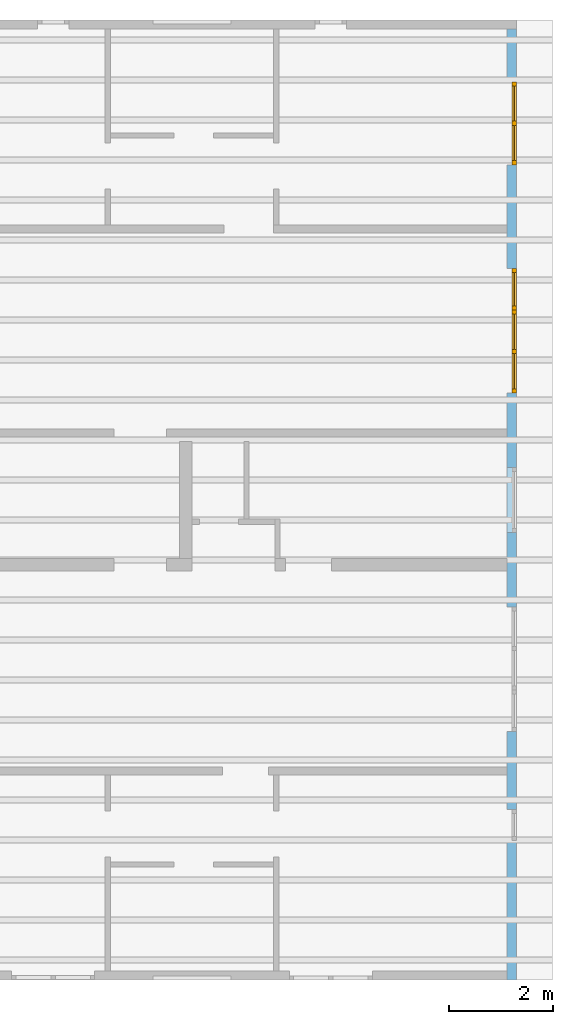
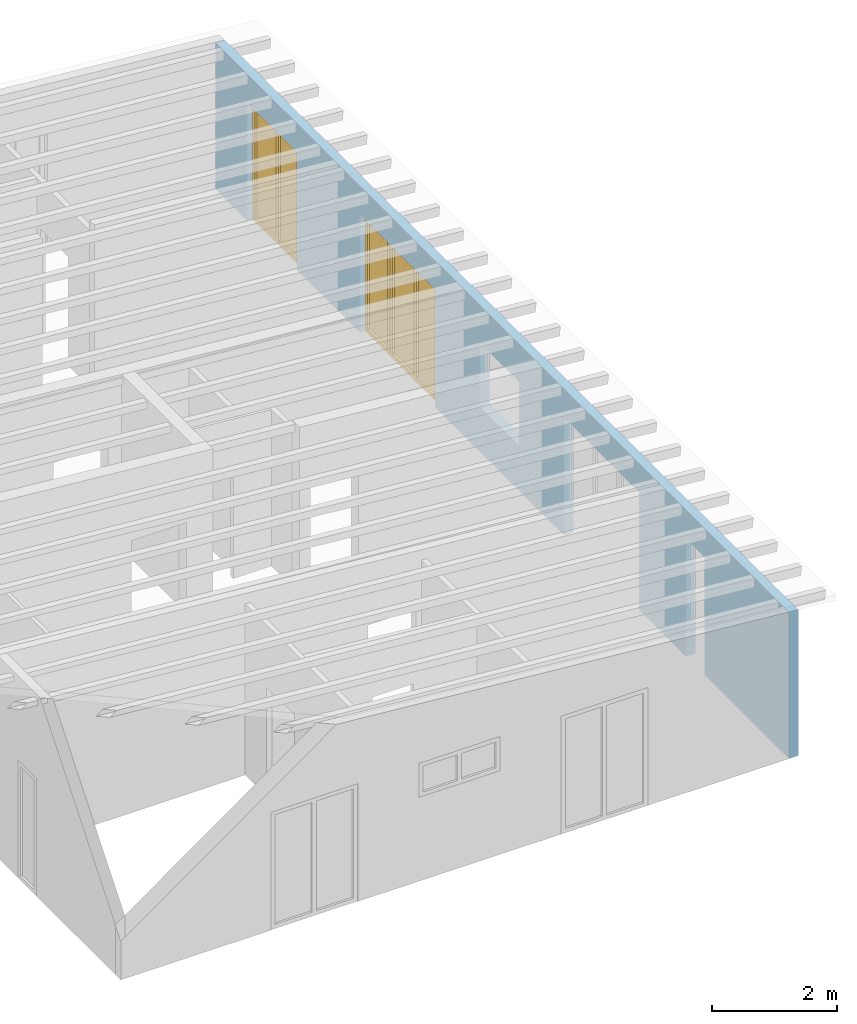
# One storey, part 10 of 13: 3 windows, 7 openings, plus 1 element that does not belong to this part.
"""IFC2X3 building model written with IfcOpenShell, lengths in millimetres."""

import ifcopenshell
import ifcopenshell.guid

model = None  # the IFC model being written
_history = None  # IfcOwnerHistory: only IFC2X3 demands one
_inside = {}  # id of a spatial element -> (the spatial element, [elements in it])
_under = {}  # id of a project, library or spatial element -> (it, [spatial elements below it])
_declared = {}  # id of a project -> (the project, [libraries it declares])
_typed = {}  # id of a type object -> (the type object, [elements of that type])
_made_of = {}  # id of a material, layer set ... -> (it, [elements and type objects made of it])


def new_model(schema):
    """Start an empty IFC model of exactly this schema.

    Asked for "IFC4X3", IfcOpenShell would pick the latest addendum, in which some entities
    have other attributes; the version numbers below select the first issue.
    IFC2X3 requires an IfcOwnerHistory on every rooted entity: one is made here for all.
    """
    global model, _history
    if schema == "IFC4X3":
        model = ifcopenshell.file(schema_version=(4, 3, 0, 0))
    else:
        model = ifcopenshell.file(schema=schema)
    _inside.clear()
    _under.clear()
    _declared.clear()
    _typed.clear()
    _made_of.clear()
    _history = None
    if model.schema == "IFC2X3":
        org = make("IfcOrganization", Name="unknown")
        user = make(
            "IfcPersonAndOrganization",
            ThePerson=make("IfcPerson", FamilyName="unknown"),
            TheOrganization=org,
        )
        app = make(
            "IfcApplication",
            ApplicationDeveloper=org,
            Version="unknown",
            ApplicationFullName="unknown",
            ApplicationIdentifier="unknown",
        )
        _history = make(
            "IfcOwnerHistory",
            OwningUser=user,
            OwningApplication=app,
            ChangeAction="ADDED",
            CreationDate=0,
        )
    return model


def make(cls, **values):
    """One entity of the class cls with the attributes given. An attribute that is None is left unset."""
    return model.create_entity(
        cls, **{name: value for name, value in values.items() if value is not None}
    )


def entity(cls, *values):
    """Any entity or typed value of the class cls, its attributes in the order of the schema. None: left unset."""
    e = model.create_entity(cls)
    for i, value in enumerate(values):
        if value is not None:
            e[i] = value
    return e


def rooted(cls, **values):
    """An entity with a GlobalId (a new one), such as an element, a storey or a relation."""
    return make(cls, GlobalId=ifcopenshell.guid.new(), OwnerHistory=_history, **values)


def si_unit(unit_type, name, prefix=None):
    """IfcSIUnit, for example si_unit("LENGTHUNIT", "METRE", prefix="MILLI")."""
    return make("IfcSIUnit", UnitType=unit_type, Prefix=prefix, Name=name)


def converted_unit(unit_type, name, factor, base, dimensions=None, offset=None):
    """IfcConversionBasedUnit, such as the inch: factor (a typed value) times the base unit."""
    return make(
        "IfcConversionBasedUnit"
        if offset is None
        else "IfcConversionBasedUnitWithOffset",
        ConversionOffset=offset,
        Dimensions=None
        if dimensions is None
        else entity("IfcDimensionalExponents", *dimensions),
        UnitType=unit_type,
        Name=name,
        ConversionFactor=make(
            "IfcMeasureWithUnit", ValueComponent=factor, UnitComponent=base
        ),
    )


def assignment(units):
    """IfcUnitAssignment: the units of a project."""
    return None if units is None else make("IfcUnitAssignment", Units=units)


def point(xyz):
    """IfcCartesianPoint."""
    return None if xyz is None else make("IfcCartesianPoint", Coordinates=xyz)


def direction(xyz):
    """IfcDirection."""
    return None if xyz is None else make("IfcDirection", DirectionRatios=xyz)


def frame(location, z_axis=None, x_axis=None):
    """IfcAxis2Placement3D, a coordinate frame: its origin and axes. An axis left out is left unset."""
    return make(
        "IfcAxis2Placement3D",
        Location=point(location),
        Axis=direction(z_axis),
        RefDirection=direction(x_axis),
    )


def frame_2d(location, x_axis=None):
    """IfcAxis2Placement2D, a coordinate frame in the plane: its origin and x axis."""
    return make(
        "IfcAxis2Placement2D", Location=point(location), RefDirection=direction(x_axis)
    )


def origin():
    """The frame at (0, 0, 0) with its axes left unset."""
    return frame((0.0, 0.0, 0.0))


def origin_with_axes():
    """The frame at (0, 0, 0) with the z axis (0, 0, 1) and the x axis (1, 0, 0) written out."""
    return frame((0.0, 0.0, 0.0), z_axis=(0.0, 0.0, 1.0), x_axis=(1.0, 0.0, 0.0))


def place(relative_to, where):
    """IfcLocalPlacement: puts the frame where relative to a parent placement (None: the world)."""
    return make(
        "IfcLocalPlacement", PlacementRelTo=relative_to, RelativePlacement=where
    )


def context(
    kind, dimensions, precision=None, world=None, true_north=None, identifier=None
):
    """IfcGeometricRepresentationContext, for example the 3D "Model" context."""
    return make(
        "IfcGeometricRepresentationContext",
        ContextIdentifier=identifier,
        ContextType=kind,
        CoordinateSpaceDimension=dimensions,
        Precision=precision,
        WorldCoordinateSystem=world,
        TrueNorth=true_north,
    )


def project(units=None, contexts=None):
    """IfcProject with its units and contexts."""
    return rooted(
        "IfcProject",
        Name="project",
        RepresentationContexts=contexts,
        UnitsInContext=assignment(units),
    )


def spatial(cls, under=None, at=None, **own):
    """A site, building, storey or space (cls), placed at a placement, below another one or the project."""
    s = rooted(cls, ObjectPlacement=at, **own)
    if under is not None:
        _under.setdefault(under.id(), (under, []))[1].append(s)
    return s


def profile(cls, at=None, kind="AREA", **sizes):
    """A parametric profile (cls). Its sizes go by their IFC names, for example OverallWidth=200.0."""
    return make(cls, ProfileType=kind, Position=at, **sizes)


def rectangle(**sizes):
    """IfcRectangleProfileDef."""
    return profile("IfcRectangleProfileDef", **sizes)


def extrude(swept, where, along, depth):
    """IfcExtrudedAreaSolid: the profile swept, set in the frame where, extruded along a direction by depth."""
    return make(
        "IfcExtrudedAreaSolid",
        SweptArea=swept,
        Position=where,
        ExtrudedDirection=direction(along),
        Depth=depth,
    )


def clip(a, b, op="DIFFERENCE"):
    """IfcBooleanClippingResult: the solid a cut by the half space b."""
    return make(
        "IfcBooleanClippingResult", Operator=op, FirstOperand=a, SecondOperand=b
    )


def halfspace(plane, agree):
    """IfcHalfSpaceSolid: all space on one side of the plane z = 0 of the frame plane."""
    return make(
        "IfcHalfSpaceSolid",
        BaseSurface=make("IfcPlane", Position=plane),
        AgreementFlag=agree,
    )


def faces_of(points, faces, orient=None, outer=None):
    """IfcFace entities. A face is a list of loops; a loop is a list of indices into points, from 0.

    orient and outer hold one flag for each loop. By default every Orientation is true, the
    first loop of a face is its IfcFaceOuterBound and the others are IfcFaceBound.
    """
    made = []
    for i, loops in enumerate(faces):
        bounds = []
        for j, loop in enumerate(loops):
            is_outer = j == 0 if outer is None else outer[i][j]
            bounds.append(
                make(
                    "IfcFaceOuterBound" if is_outer else "IfcFaceBound",
                    Bound=make("IfcPolyLoop", Polygon=[points[k] for k in loop]),
                    Orientation=True if orient is None else orient[i][j],
                )
            )
        made.append(make("IfcFace", Bounds=bounds))
    return made


def faceted_brep(points, faces, orient=None, outer=None, voids=None):
    """IfcFacetedBrep: a solid bounded by flat faces; with voids (closed shells), ...WithVoids."""
    shared = [point(p) for p in points]
    hull = make("IfcClosedShell", CfsFaces=faces_of(shared, faces, orient, outer))
    if voids is None:
        return make("IfcFacetedBrep", Outer=hull)
    return make(
        "IfcFacetedBrepWithVoids",
        Outer=hull,
        Voids=[
            make(cls, CfsFaces=faces_of(shared, fs, o, b)) for cls, fs, o, b in voids
        ],
    )


def shape(context_of_items, identifier, shape_type, items):
    """IfcShapeRepresentation: the items that make up one representation, for example the "Body"."""
    return make(
        "IfcShapeRepresentation",
        ContextOfItems=context_of_items,
        RepresentationIdentifier=identifier,
        RepresentationType=shape_type,
        Items=items,
    )


def material(Name=None, Category=None):
    """IfcMaterial."""
    return make("IfcMaterial", Name=Name, Category=Category)


def layer(
    of_material, thickness, ventilated=None, Name=None, Category=None, Priority=None
):
    """IfcMaterialLayer: one layer of a wall or slab, of a material (None: an air gap)."""
    return make(
        "IfcMaterialLayer",
        Material=of_material,
        LayerThickness=thickness,
        IsVentilated=ventilated,
        Name=Name,
        Category=Category,
        Priority=Priority,
    )


def layer_set(layers, Name=None):
    """IfcMaterialLayerSet."""
    return make("IfcMaterialLayerSet", MaterialLayers=layers, LayerSetName=Name)


def layer_usage(for_layer_set, set_direction, sense, offset, extent=None):
    """IfcMaterialLayerSetUsage: how a layer set lies in its element."""
    return make(
        "IfcMaterialLayerSetUsage",
        ForLayerSet=for_layer_set,
        LayerSetDirection=set_direction,
        DirectionSense=sense,
        OffsetFromReferenceLine=offset,
        ReferenceExtent=extent,
    )


def made_of(thing, what):
    """Note that an element or type object is made of a material, layer set ...; save() writes the relation."""
    if what is not None:
        _made_of.setdefault(what.id(), (what, []))[1].append(thing)
    return thing


def element(
    cls,
    number,
    at=None,
    inside=None,
    cuts=None,
    type_object=None,
    material=None,
    context=None,
    identifier="Body",
    shape_type=None,
    held_by="IfcProductDefinitionShape",
    body=None,
    shapes=None,
    **own,
):
    """One element of the class cls, such as IfcWall. Its Tag is "e" and its number.

    at: its placement. inside: the storey or other place that contains it. cuts: it is an
    opening in that element (IfcRelVoidsElement). A single representation is given by context,
    identifier, shape_type and body (its items); several are given by shapes. held_by: the class
    of the entity that holds the representations. save() writes the other relations.
    """
    e = rooted(cls, Tag="e%d" % number, ObjectPlacement=at, **own)
    if body is not None:
        shapes = [shape(context, identifier, shape_type, body)]
    if shapes is not None:
        e.Representation = make(held_by, Representations=shapes)
    if inside is not None:
        _inside.setdefault(inside.id(), (inside, []))[1].append(e)
    if cuts is not None:
        rooted(
            "IfcRelVoidsElement", RelatingBuildingElement=cuts, RelatedOpeningElement=e
        )
    if type_object is not None:
        _typed.setdefault(type_object.id(), (type_object, []))[1].append(e)
    return made_of(e, material)


def fill(opening, filler):
    """IfcRelFillsElement: the door or window that sits in an opening."""
    return rooted(
        "IfcRelFillsElement",
        RelatingOpeningElement=opening,
        RelatedBuildingElement=filler,
    )


def aggregate(whole, parts):
    """IfcRelAggregates: a whole, such as a stair, and the parts it consists of."""
    return rooted("IfcRelAggregates", RelatingObject=whole, RelatedObjects=parts)


def save(model, path):
    """Write the relations noted so far, then the file.

    IfcRelAggregates (storeys below a building ...), IfcRelContainedInSpatialStructure (elements
    in a storey), IfcRelDefinesByType, IfcRelAssociatesMaterial and IfcRelDeclares: one each for
    every whole, place, type object, material and project.
    """
    for whole, parts in _under.values():
        aggregate(whole, parts)
    for where, things in _inside.values():
        rooted(
            "IfcRelContainedInSpatialStructure",
            RelatedElements=things,
            RelatingStructure=where,
        )
    for kind, things in _typed.values():
        rooted("IfcRelDefinesByType", RelatedObjects=things, RelatingType=kind)
    for what, things in _made_of.values():
        rooted("IfcRelAssociatesMaterial", RelatedObjects=things, RelatingMaterial=what)
    for by, libraries in _declared.values():
        rooted("IfcRelDeclares", RelatingContext=by, RelatedDefinitions=libraries)
    model.write(path)


model = new_model("IFC2X3")

# Units and contexts
model_context = context("Model", 3, precision=1e-05, world=origin())
plan_context = context("Plan", 3, precision=1e-05, world=origin())
ifc_project = project(units=[si_unit("LENGTHUNIT", "METRE", prefix="MILLI"), converted_unit("PLANEANGLEUNIT", "DEGREE", entity("IfcPlaneAngleMeasure", 0.0174532925199433), si_unit("PLANEANGLEUNIT", "RADIAN"), dimensions=[0, 0, 0, 0, 0, 0, 0]), si_unit("AREAUNIT", "SQUARE_METRE"), si_unit("VOLUMEUNIT", "CUBIC_METRE")], contexts=[model_context, plan_context])

# Building, storey
building_placement = place(None, origin())
building = spatial("IfcBuilding", under=ifc_project, at=building_placement, CompositionType="ELEMENT")
storey_placement = place(building_placement, frame((0.0, 0.0, 4770.0), z_axis=(0.0, 0.0, 1.0), x_axis=(1.0, 0.0, 0.0)))
storey = spatial("IfcBuildingStorey", under=building, at=storey_placement, Name="Geschoss", CompositionType="ELEMENT", Elevation=4770.0)

# Wall, openings, windows
ifc_material_1 = material()
ifc_layer = layer(ifc_material_1, 175.000000044703)
ifc_layer_set = layer_set([ifc_layer])
ifc_layer_usage = layer_usage(ifc_layer_set, "AXIS2", "POSITIVE", 0.0)
wall_placement = place(storey_placement, frame((33688.3517822139, -8691.5625, 0.0), z_axis=(0.0, 0.0, 1.0), x_axis=(0.0, 1.0, 0.0)))
wall = element("IfcWallStandardCase", 1, at=wall_placement, inside=storey, material=ifc_layer_usage, context=model_context, shape_type="Clipping", body=[
    clip(extrude(rectangle(XDim=18325.0, YDim=175.000000044703, at=frame_2d((9162.5, 87.5000000223517), x_axis=(1.0, 0.0))), origin_with_axes(), (0.0, 0.0, 1.0), 2862.31051612095), halfspace(frame((18325.0, 175.000000044703, 2862.31051612095), z_axis=(0.0, 0.0871557427476584, -0.996194698091746), x_axis=(1.0, 0.0, 0.0)), True)),
])
opening_1_placement = place(wall_placement, frame((8625.0, 1.86264514923096e-09, 875.0), z_axis=(0.0, 1.0, 0.0), x_axis=(0.0, 0.0, 1.0)))
element("IfcOpeningElement", 2, at=opening_1_placement, cuts=wall, ObjectType="Opening", context=model_context, shape_type="SweptSolid", body=[
    extrude(rectangle(XDim=1250.0, YDim=1250.0, at=frame_2d((625.0, 625.0), x_axis=(1.0, 0.0))), origin_with_axes(), (0.0, 0.0, 1.0), 175.000000044703),
])
opening_2_placement = place(wall_placement, frame((5590.0, 0.0, 0.0), z_axis=(0.0, 1.0, 0.0), x_axis=(0.0, 0.0, 1.0)))
element("IfcOpeningElement", 3, at=opening_2_placement, cuts=wall, ObjectType="Opening", context=model_context, shape_type="SweptSolid", body=[
    extrude(rectangle(XDim=2300.0, YDim=1600.0, at=frame_2d((1150.0, 800.0), x_axis=(1.0, 0.0))), origin_with_axes(), (0.0, 0.0, 1.0), 175.000000044703),
])
opening_3_placement = place(wall_placement, frame((2690.0, 0.0, 0.0), z_axis=(0.0, 1.0, 0.0), x_axis=(0.0, 0.0, 1.0)))
element("IfcOpeningElement", 4, at=opening_3_placement, cuts=wall, ObjectType="Opening", context=model_context, shape_type="SweptSolid", body=[
    extrude(rectangle(XDim=2300.0, YDim=600.0, at=frame_2d((1150.0, 300.0), x_axis=(1.0, 0.0))), origin_with_axes(), (0.0, 0.0, 1.0), 175.000000044703),
])
opening_4_placement = place(wall_placement, frame((11310.0, 0.0, 0.0), z_axis=(0.0, 1.0, 0.0), x_axis=(0.0, 0.0, 1.0)))
opening_4 = element("IfcOpeningElement", 5, at=opening_4_placement, cuts=wall, ObjectType="Opening", context=model_context, shape_type="SweptSolid", body=[
    extrude(rectangle(XDim=2300.0, YDim=1600.0, at=frame_2d((1150.0, 800.0), x_axis=(1.0, 0.0))), origin_with_axes(), (0.0, 0.0, 1.0), 175.000000044703),
])
opening_5_placement = place(wall_placement, frame((15710.0, 0.0, 0.0), z_axis=(0.0, 1.0, 0.0), x_axis=(0.0, 0.0, 1.0)))
opening_5 = element("IfcOpeningElement", 6, at=opening_5_placement, cuts=wall, ObjectType="Opening", context=model_context, shape_type="SweptSolid", body=[
    extrude(rectangle(XDim=2300.0, YDim=1600.0, at=frame_2d((1150.0, 800.0), x_axis=(1.0, 0.0))), origin_with_axes(), (0.0, 0.0, 1.0), 175.000000044703),
])
opening_6_placement = place(wall_placement, frame((12910.0, 0.0, 0.0), z_axis=(0.0, 1.0, 0.0), x_axis=(0.0, 0.0, 1.0)))
opening_6 = element("IfcOpeningElement", 7, at=opening_6_placement, cuts=wall, ObjectType="Opening", context=model_context, shape_type="SweptSolid", body=[
    extrude(rectangle(XDim=2300.0, YDim=800.0, at=frame_2d((1150.0, 400.0), x_axis=(1.0, 0.0))), origin_with_axes(), (0.0, 0.0, 1.0), 175.000000044703),
])
opening_7_placement = place(wall_placement, frame((4790.0, 0.0, 0.0), z_axis=(0.0, 1.0, 0.0), x_axis=(0.0, 0.0, 1.0)))
element("IfcOpeningElement", 8, at=opening_7_placement, cuts=wall, ObjectType="Opening", context=model_context, shape_type="SweptSolid", body=[
    extrude(rectangle(XDim=2300.0, YDim=800.0, at=frame_2d((1150.0, 400.0), x_axis=(1.0, 0.0))), origin_with_axes(), (0.0, 0.0, 1.0), 175.000000044703),
])
ifc_material_2 = material()
window_1_placement = place(opening_4_placement, frame((0.0, 0.0, 0.0), z_axis=(1.0, 0.0, 0.0), x_axis=(0.0, 1.0, 0.0)))
window_1 = element("IfcWindow", 9, at=window_1_placement, inside=storey, material=ifc_material_2, Name="m", OverallHeight=2300.0, OverallWidth=1600.0, context=model_context, shape_type="Brep", body=[
    faceted_brep([(1520.0, 4.14689393934964e-11, 0.0), (1520.0, 4.14689393934964e-11, 2300.0), (1600.0, 4.14542844495713e-11, 2300.0), (1600.0, 4.14542844495713e-11, 0.0), (1600.0, 80.0000000000415, 0.0), (1600.0, 80.0000000000415, 2300.0), (1520.0, 80.0000000000415, 2300.0), (1520.0, 80.0000000000415, 0.0), (1600.0, 4.14542844495713e-11, 0.0), (1600.0, 80.0000000000415, 0.0), (1520.0, 80.0000000000415, 0.0), (1520.0, 4.14689393934964e-11, 0.0), (1600.0, 4.14542844495713e-11, 2300.0), (1600.0, 80.0000000000415, 2300.0), (1600.0, 80.0000000000415, 0.0), (1600.0, 4.14542844495713e-11, 0.0), (1520.0, 4.14689393934964e-11, 2300.0), (1520.0, 80.0000000000415, 2300.0), (1600.0, 80.0000000000415, 2300.0), (1600.0, 4.14542844495713e-11, 2300.0), (1520.0, 4.14689393934964e-11, 0.0), (1520.0, 80.0000000000415, 0.0), (1520.0, 80.0000000000415, 2300.0), (1520.0, 4.14689393934964e-11, 2300.0)], [[[0, 1, 2, 3]], [[4, 5, 6, 7]], [[8, 9, 10, 11]], [[12, 13, 14, 15]], [[16, 17, 18, 19]], [[20, 21, 22, 23]]], orient=[[False], [False], [False], [False], [False], [False]]),
    faceted_brep([(80.0, 4.17335055402646e-11, 2300.0), (80.0, 4.17335055402646e-11, 0.0), (-1.10214571841424e-16, 4.17481604841896e-11, 0.0), (-1.10214571841424e-16, 4.17481604841896e-11, 2300.0), (1.45850616740271e-14, 80.0000000000418, 2300.0), (1.45850616740271e-14, 80.0000000000418, 0.0), (80.0, 80.0000000000417, 0.0), (80.0, 80.0000000000417, 2300.0), (-1.10214571841424e-16, 4.17481604841896e-11, 2300.0), (1.45850616740271e-14, 80.0000000000418, 2300.0), (80.0, 80.0000000000417, 2300.0), (80.0, 4.17335055402646e-11, 2300.0), (-1.10214571841424e-16, 4.17481604841896e-11, 0.0), (1.45850616740271e-14, 80.0000000000418, 0.0), (1.45850616740271e-14, 80.0000000000418, 2300.0), (-1.10214571841424e-16, 4.17481604841896e-11, 2300.0), (80.0, 4.17335055402646e-11, 0.0), (80.0, 80.0000000000417, 0.0), (1.45850616740271e-14, 80.0000000000418, 0.0), (-1.10214571841424e-16, 4.17481604841896e-11, 0.0), (80.0, 4.17335055402646e-11, 2300.0), (80.0, 80.0000000000417, 2300.0), (80.0, 80.0000000000417, 0.0), (80.0, 4.17335055402646e-11, 0.0)], [[[0, 1, 2, 3]], [[4, 5, 6, 7]], [[8, 9, 10, 11]], [[12, 13, 14, 15]], [[16, 17, 18, 19]], [[20, 21, 22, 23]]], orient=[[False], [False], [False], [False], [False], [False]]),
    faceted_brep([(1520.0, 4.14831502482116e-11, 2220.0), (80.0, 4.17477163949798e-11, 2220.0), (80.0, 4.17477163949798e-11, 2300.0), (1520.0, 4.14831502482116e-11, 2300.0), (1520.0, 80.0000000000415, 2300.0), (80.0, 80.0000000000418, 2300.0), (80.0, 80.0000000000418, 2220.0), (1520.0, 80.0000000000415, 2220.0), (1520.0, 4.14831502482116e-11, 2300.0), (1520.0, 80.0000000000415, 2300.0), (1520.0, 80.0000000000415, 2220.0), (1520.0, 4.14831502482116e-11, 2220.0), (80.0, 4.17477163949798e-11, 2300.0), (80.0, 80.0000000000418, 2300.0), (1520.0, 80.0000000000415, 2300.0), (1520.0, 4.14831502482116e-11, 2300.0), (80.0, 4.17477163949798e-11, 2220.0), (80.0, 80.0000000000418, 2220.0), (80.0, 80.0000000000418, 2300.0), (80.0, 4.17477163949798e-11, 2300.0), (1520.0, 4.14831502482116e-11, 2220.0), (1520.0, 80.0000000000415, 2220.0), (80.0, 80.0000000000418, 2220.0), (80.0, 4.17477163949798e-11, 2220.0)], [[[0, 1, 2, 3]], [[4, 5, 6, 7]], [[8, 9, 10, 11]], [[12, 13, 14, 15]], [[16, 17, 18, 19]], [[20, 21, 22, 23]]], orient=[[False], [False], [False], [False], [False], [False]]),
    faceted_brep([(80.0, 4.17477163949798e-11, 80.0), (1520.0, 4.14831502482116e-11, 80.0), (1520.0, 4.14831502482116e-11, 0.0), (80.0, 4.17477163949798e-11, 0.0), (80.0, 80.0000000000418, 0.0), (1520.0, 80.0000000000415, 0.0), (1520.0, 80.0000000000415, 80.0), (80.0, 80.0000000000418, 80.0), (80.0, 4.17477163949798e-11, 0.0), (80.0, 80.0000000000418, 0.0), (80.0, 80.0000000000418, 80.0), (80.0, 4.17477163949798e-11, 80.0), (1520.0, 4.14831502482116e-11, 0.0), (1520.0, 80.0000000000415, 0.0), (80.0, 80.0000000000418, 0.0), (80.0, 4.17477163949798e-11, 0.0), (1520.0, 4.14831502482116e-11, 80.0), (1520.0, 80.0000000000415, 80.0), (1520.0, 80.0000000000415, 0.0), (1520.0, 4.14831502482116e-11, 0.0), (80.0, 4.17477163949798e-11, 80.0), (80.0, 80.0000000000418, 80.0), (1520.0, 80.0000000000415, 80.0), (1520.0, 4.14831502482116e-11, 80.0)], [[[0, 1, 2, 3]], [[4, 5, 6, 7]], [[8, 9, 10, 11]], [[12, 13, 14, 15]], [[16, 17, 18, 19]], [[20, 21, 22, 23]]], orient=[[False], [False], [False], [False], [False], [False]]),
    faceted_brep([(760.0, 4.16086054499942e-11, 80.0), (760.0, 4.16086054499942e-11, 2220.0), (840.0, 4.15938394837667e-11, 2220.0), (840.0, 4.15938394837667e-11, 80.0), (840.0, 80.0000000000416, 80.0), (840.0, 80.0000000000416, 2220.0), (760.0, 80.0000000000416, 2220.0), (760.0, 80.0000000000416, 80.0), (840.0, 4.15938394837667e-11, 80.0), (840.0, 80.0000000000416, 80.0), (760.0, 80.0000000000416, 80.0), (760.0, 4.16086054499942e-11, 80.0), (840.0, 4.15938394837667e-11, 2220.0), (840.0, 80.0000000000416, 2220.0), (840.0, 80.0000000000416, 80.0), (840.0, 4.15938394837667e-11, 80.0), (760.0, 4.16086054499942e-11, 2220.0), (760.0, 80.0000000000416, 2220.0), (840.0, 80.0000000000416, 2220.0), (840.0, 4.15938394837667e-11, 2220.0), (760.0, 4.16086054499942e-11, 80.0), (760.0, 80.0000000000416, 80.0), (760.0, 80.0000000000416, 2220.0), (760.0, 4.16086054499942e-11, 2220.0)], [[[0, 1, 2, 3]], [[4, 5, 6, 7]], [[8, 9, 10, 11]], [[12, 13, 14, 15]], [[16, 17, 18, 19]], [[20, 21, 22, 23]]], orient=[[False], [False], [False], [False], [False], [False]]),
    faceted_brep([(80.0, 40.0000000000418, 2220.0), (760.0, 40.0000000000416, 2220.0), (760.0, 40.0000000000416, 80.0), (80.0, 40.0000000000418, 80.0), (80.0, 41.0000000000418, 2220.0), (80.0, 41.0000000000418, 80.0), (760.0, 41.0000000000416, 80.0), (760.0, 41.0000000000416, 2220.0), (80.0, 40.0000000000418, 2220.0), (80.0, 41.0000000000418, 2220.0), (760.0, 41.0000000000416, 2220.0), (760.0, 40.0000000000416, 2220.0), (760.0, 40.0000000000416, 2220.0), (760.0, 41.0000000000416, 2220.0), (760.0, 41.0000000000416, 80.0), (760.0, 40.0000000000416, 80.0), (760.0, 40.0000000000416, 80.0), (760.0, 41.0000000000416, 80.0), (80.0, 41.0000000000418, 80.0), (80.0, 40.0000000000418, 80.0), (80.0, 40.0000000000418, 80.0), (80.0, 41.0000000000418, 80.0), (80.0, 41.0000000000418, 2220.0), (80.0, 40.0000000000418, 2220.0)], [[[0, 1, 2, 3]], [[4, 5, 6, 7]], [[8, 9, 10, 11]], [[12, 13, 14, 15]], [[16, 17, 18, 19]], [[20, 21, 22, 23]]], orient=[[False], [False], [False], [False], [False], [False]]),
    faceted_brep([(1520.0, 40.0000000000415, 80.0), (840.0, 40.0000000000416, 80.0), (840.0, 40.0000000000416, 2220.0), (1520.0, 40.0000000000415, 2220.0), (1520.0, 41.0000000000415, 80.0), (1520.0, 41.0000000000415, 2220.0), (840.0, 41.0000000000416, 2220.0), (840.0, 41.0000000000416, 80.0), (1520.0, 40.0000000000415, 80.0), (1520.0, 41.0000000000415, 80.0), (840.0, 41.0000000000416, 80.0), (840.0, 40.0000000000416, 80.0), (840.0, 40.0000000000416, 80.0), (840.0, 41.0000000000416, 80.0), (840.0, 41.0000000000416, 2220.0), (840.0, 40.0000000000416, 2220.0), (840.0, 40.0000000000416, 2220.0), (840.0, 41.0000000000416, 2220.0), (1520.0, 41.0000000000415, 2220.0), (1520.0, 40.0000000000415, 2220.0), (1520.0, 40.0000000000415, 2220.0), (1520.0, 41.0000000000415, 2220.0), (1520.0, 41.0000000000415, 80.0), (1520.0, 40.0000000000415, 80.0)], [[[0, 1, 2, 3]], [[4, 5, 6, 7]], [[8, 9, 10, 11]], [[12, 13, 14, 15]], [[16, 17, 18, 19]], [[20, 21, 22, 23]]], orient=[[False], [False], [False], [False], [False], [False]]),
])
fill(opening_4, window_1)
ifc_material_3 = material()
window_2_placement = place(opening_5_placement, frame((0.0, 0.0, 0.0), z_axis=(1.0, 0.0, 0.0), x_axis=(0.0, 1.0, 0.0)))
window_2 = element("IfcWindow", 10, at=window_2_placement, inside=storey, material=ifc_material_3, Name="m", OverallHeight=2300.0, OverallWidth=1600.0, context=model_context, shape_type="Brep", body=[
    faceted_brep([(1520.0, 4.14689393934964e-11, 0.0), (1520.0, 4.14689393934964e-11, 2300.0), (1600.0, 4.14542844495713e-11, 2300.0), (1600.0, 4.14542844495713e-11, 0.0), (1600.0, 80.0000000000415, 0.0), (1600.0, 80.0000000000415, 2300.0), (1520.0, 80.0000000000415, 2300.0), (1520.0, 80.0000000000415, 0.0), (1600.0, 4.14542844495713e-11, 0.0), (1600.0, 80.0000000000415, 0.0), (1520.0, 80.0000000000415, 0.0), (1520.0, 4.14689393934964e-11, 0.0), (1600.0, 4.14542844495713e-11, 2300.0), (1600.0, 80.0000000000415, 2300.0), (1600.0, 80.0000000000415, 0.0), (1600.0, 4.14542844495713e-11, 0.0), (1520.0, 4.14689393934964e-11, 2300.0), (1520.0, 80.0000000000415, 2300.0), (1600.0, 80.0000000000415, 2300.0), (1600.0, 4.14542844495713e-11, 2300.0), (1520.0, 4.14689393934964e-11, 0.0), (1520.0, 80.0000000000415, 0.0), (1520.0, 80.0000000000415, 2300.0), (1520.0, 4.14689393934964e-11, 2300.0)], [[[0, 1, 2, 3]], [[4, 5, 6, 7]], [[8, 9, 10, 11]], [[12, 13, 14, 15]], [[16, 17, 18, 19]], [[20, 21, 22, 23]]], orient=[[False], [False], [False], [False], [False], [False]]),
    faceted_brep([(80.0, 4.17335055402646e-11, 2300.0), (80.0, 4.17335055402646e-11, 0.0), (-1.10214571841424e-16, 4.17481604841896e-11, 0.0), (-1.10214571841424e-16, 4.17481604841896e-11, 2300.0), (1.45850616740271e-14, 80.0000000000418, 2300.0), (1.45850616740271e-14, 80.0000000000418, 0.0), (80.0, 80.0000000000417, 0.0), (80.0, 80.0000000000417, 2300.0), (-1.10214571841424e-16, 4.17481604841896e-11, 2300.0), (1.45850616740271e-14, 80.0000000000418, 2300.0), (80.0, 80.0000000000417, 2300.0), (80.0, 4.17335055402646e-11, 2300.0), (-1.10214571841424e-16, 4.17481604841896e-11, 0.0), (1.45850616740271e-14, 80.0000000000418, 0.0), (1.45850616740271e-14, 80.0000000000418, 2300.0), (-1.10214571841424e-16, 4.17481604841896e-11, 2300.0), (80.0, 4.17335055402646e-11, 0.0), (80.0, 80.0000000000417, 0.0), (1.45850616740271e-14, 80.0000000000418, 0.0), (-1.10214571841424e-16, 4.17481604841896e-11, 0.0), (80.0, 4.17335055402646e-11, 2300.0), (80.0, 80.0000000000417, 2300.0), (80.0, 80.0000000000417, 0.0), (80.0, 4.17335055402646e-11, 0.0)], [[[0, 1, 2, 3]], [[4, 5, 6, 7]], [[8, 9, 10, 11]], [[12, 13, 14, 15]], [[16, 17, 18, 19]], [[20, 21, 22, 23]]], orient=[[False], [False], [False], [False], [False], [False]]),
    faceted_brep([(1520.0, 4.14831502482116e-11, 2220.0), (80.0, 4.17477163949798e-11, 2220.0), (80.0, 4.17477163949798e-11, 2300.0), (1520.0, 4.14831502482116e-11, 2300.0), (1520.0, 80.0000000000415, 2300.0), (80.0, 80.0000000000418, 2300.0), (80.0, 80.0000000000418, 2220.0), (1520.0, 80.0000000000415, 2220.0), (1520.0, 4.14831502482116e-11, 2300.0), (1520.0, 80.0000000000415, 2300.0), (1520.0, 80.0000000000415, 2220.0), (1520.0, 4.14831502482116e-11, 2220.0), (80.0, 4.17477163949798e-11, 2300.0), (80.0, 80.0000000000418, 2300.0), (1520.0, 80.0000000000415, 2300.0), (1520.0, 4.14831502482116e-11, 2300.0), (80.0, 4.17477163949798e-11, 2220.0), (80.0, 80.0000000000418, 2220.0), (80.0, 80.0000000000418, 2300.0), (80.0, 4.17477163949798e-11, 2300.0), (1520.0, 4.14831502482116e-11, 2220.0), (1520.0, 80.0000000000415, 2220.0), (80.0, 80.0000000000418, 2220.0), (80.0, 4.17477163949798e-11, 2220.0)], [[[0, 1, 2, 3]], [[4, 5, 6, 7]], [[8, 9, 10, 11]], [[12, 13, 14, 15]], [[16, 17, 18, 19]], [[20, 21, 22, 23]]], orient=[[False], [False], [False], [False], [False], [False]]),
    faceted_brep([(80.0, 4.17477163949798e-11, 80.0), (1520.0, 4.14831502482116e-11, 80.0), (1520.0, 4.14831502482116e-11, 0.0), (80.0, 4.17477163949798e-11, 0.0), (80.0, 80.0000000000418, 0.0), (1520.0, 80.0000000000415, 0.0), (1520.0, 80.0000000000415, 80.0), (80.0, 80.0000000000418, 80.0), (80.0, 4.17477163949798e-11, 0.0), (80.0, 80.0000000000418, 0.0), (80.0, 80.0000000000418, 80.0), (80.0, 4.17477163949798e-11, 80.0), (1520.0, 4.14831502482116e-11, 0.0), (1520.0, 80.0000000000415, 0.0), (80.0, 80.0000000000418, 0.0), (80.0, 4.17477163949798e-11, 0.0), (1520.0, 4.14831502482116e-11, 80.0), (1520.0, 80.0000000000415, 80.0), (1520.0, 80.0000000000415, 0.0), (1520.0, 4.14831502482116e-11, 0.0), (80.0, 4.17477163949798e-11, 80.0), (80.0, 80.0000000000418, 80.0), (1520.0, 80.0000000000415, 80.0), (1520.0, 4.14831502482116e-11, 80.0)], [[[0, 1, 2, 3]], [[4, 5, 6, 7]], [[8, 9, 10, 11]], [[12, 13, 14, 15]], [[16, 17, 18, 19]], [[20, 21, 22, 23]]], orient=[[False], [False], [False], [False], [False], [False]]),
    faceted_brep([(760.000000000001, 4.16086054499942e-11, 80.0), (760.000000000001, 4.16086054499942e-11, 2220.0), (840.000000000001, 4.15938394837667e-11, 2220.0), (840.000000000001, 4.15938394837667e-11, 80.0), (840.000000000001, 80.0000000000416, 80.0), (840.000000000001, 80.0000000000416, 2220.0), (760.000000000001, 80.0000000000416, 2220.0), (760.000000000001, 80.0000000000416, 80.0), (840.000000000001, 4.15938394837667e-11, 80.0), (840.000000000001, 80.0000000000416, 80.0), (760.000000000001, 80.0000000000416, 80.0), (760.000000000001, 4.16086054499942e-11, 80.0), (840.000000000001, 4.15938394837667e-11, 2220.0), (840.000000000001, 80.0000000000416, 2220.0), (840.000000000001, 80.0000000000416, 80.0), (840.000000000001, 4.15938394837667e-11, 80.0), (760.000000000001, 4.16086054499942e-11, 2220.0), (760.000000000001, 80.0000000000416, 2220.0), (840.000000000001, 80.0000000000416, 2220.0), (840.000000000001, 4.15938394837667e-11, 2220.0), (760.000000000001, 4.16086054499942e-11, 80.0), (760.000000000001, 80.0000000000416, 80.0), (760.000000000001, 80.0000000000416, 2220.0), (760.000000000001, 4.16086054499942e-11, 2220.0)], [[[0, 1, 2, 3]], [[4, 5, 6, 7]], [[8, 9, 10, 11]], [[12, 13, 14, 15]], [[16, 17, 18, 19]], [[20, 21, 22, 23]]], orient=[[False], [False], [False], [False], [False], [False]]),
    faceted_brep([(80.0, 40.0000000000418, 2220.0), (760.000000000001, 40.0000000000416, 2220.0), (760.000000000001, 40.0000000000416, 80.0), (80.0, 40.0000000000418, 80.0), (80.0, 41.0000000000418, 2220.0), (80.0, 41.0000000000418, 80.0), (760.000000000001, 41.0000000000416, 80.0), (760.000000000001, 41.0000000000416, 2220.0), (80.0, 40.0000000000418, 2220.0), (80.0, 41.0000000000418, 2220.0), (760.000000000001, 41.0000000000416, 2220.0), (760.000000000001, 40.0000000000416, 2220.0), (760.000000000001, 40.0000000000416, 2220.0), (760.000000000001, 41.0000000000416, 2220.0), (760.000000000001, 41.0000000000416, 80.0), (760.000000000001, 40.0000000000416, 80.0), (760.000000000001, 40.0000000000416, 80.0), (760.000000000001, 41.0000000000416, 80.0), (80.0, 41.0000000000418, 80.0), (80.0, 40.0000000000418, 80.0), (80.0, 40.0000000000418, 80.0), (80.0, 41.0000000000418, 80.0), (80.0, 41.0000000000418, 2220.0), (80.0, 40.0000000000418, 2220.0)], [[[0, 1, 2, 3]], [[4, 5, 6, 7]], [[8, 9, 10, 11]], [[12, 13, 14, 15]], [[16, 17, 18, 19]], [[20, 21, 22, 23]]], orient=[[False], [False], [False], [False], [False], [False]]),
    faceted_brep([(1520.0, 40.0000000000415, 80.0), (840.000000000001, 40.0000000000416, 80.0), (840.000000000001, 40.0000000000416, 2220.0), (1520.0, 40.0000000000415, 2220.0), (1520.0, 41.0000000000415, 80.0), (1520.0, 41.0000000000415, 2220.0), (840.000000000001, 41.0000000000416, 2220.0), (840.000000000001, 41.0000000000416, 80.0), (1520.0, 40.0000000000415, 80.0), (1520.0, 41.0000000000415, 80.0), (840.000000000001, 41.0000000000416, 80.0), (840.000000000001, 40.0000000000416, 80.0), (840.000000000001, 40.0000000000416, 80.0), (840.000000000001, 41.0000000000416, 80.0), (840.000000000001, 41.0000000000416, 2220.0), (840.000000000001, 40.0000000000416, 2220.0), (840.000000000001, 40.0000000000416, 2220.0), (840.000000000001, 41.0000000000416, 2220.0), (1520.0, 41.0000000000415, 2220.0), (1520.0, 40.0000000000415, 2220.0), (1520.0, 40.0000000000415, 2220.0), (1520.0, 41.0000000000415, 2220.0), (1520.0, 41.0000000000415, 80.0), (1520.0, 40.0000000000415, 80.0)], [[[0, 1, 2, 3]], [[4, 5, 6, 7]], [[8, 9, 10, 11]], [[12, 13, 14, 15]], [[16, 17, 18, 19]], [[20, 21, 22, 23]]], orient=[[False], [False], [False], [False], [False], [False]]),
])
fill(opening_5, window_2)
ifc_material_4 = material()
window_3_placement = place(opening_6_placement, frame((0.0, 0.0, 0.0), z_axis=(1.0, 0.0, 0.0), x_axis=(0.0, 1.0, 0.0)))
window_3 = element("IfcWindow", 11, at=window_3_placement, inside=storey, material=ifc_material_4, Name="m", OverallHeight=2300.0, OverallWidth=800.0, context=model_context, shape_type="Brep", body=[
    faceted_brep([(720.0, 4.16017220672416e-11, 0.0), (720.0, 4.16017220672416e-11, 2300.0), (800.0, 4.1586956101014e-11, 2300.0), (800.0, 4.1586956101014e-11, 0.0), (800.0, 80.0000000000416, 0.0), (800.0, 80.0000000000416, 2300.0), (720.0, 80.0000000000416, 2300.0), (720.0, 80.0000000000416, 0.0), (800.0, 4.1586956101014e-11, 0.0), (800.0, 80.0000000000416, 0.0), (720.0, 80.0000000000416, 0.0), (720.0, 4.16017220672416e-11, 0.0), (800.0, 4.1586956101014e-11, 2300.0), (800.0, 80.0000000000416, 2300.0), (800.0, 80.0000000000416, 0.0), (800.0, 4.1586956101014e-11, 0.0), (720.0, 4.16017220672416e-11, 2300.0), (720.0, 80.0000000000416, 2300.0), (800.0, 80.0000000000416, 2300.0), (800.0, 4.1586956101014e-11, 2300.0), (720.0, 4.16017220672416e-11, 0.0), (720.0, 80.0000000000416, 0.0), (720.0, 80.0000000000416, 2300.0), (720.0, 4.16017220672416e-11, 2300.0)], [[[0, 1, 2, 3]], [[4, 5, 6, 7]], [[8, 9, 10, 11]], [[12, 13, 14, 15]], [[16, 17, 18, 19]], [[20, 21, 22, 23]]], orient=[[False], [False], [False], [False], [False], [False]]),
    faceted_brep([(80.0, 4.17335055402646e-11, 2300.0), (80.0, 4.17335055402646e-11, 0.0), (-1.10214571841424e-16, 4.17481604841896e-11, 0.0), (-1.10214571841424e-16, 4.17481604841896e-11, 2300.0), (1.45850616740271e-14, 80.0000000000418, 2300.0), (1.45850616740271e-14, 80.0000000000418, 0.0), (80.0, 80.0000000000417, 0.0), (80.0, 80.0000000000417, 2300.0), (-1.10214571841424e-16, 4.17481604841896e-11, 2300.0), (1.45850616740271e-14, 80.0000000000418, 2300.0), (80.0, 80.0000000000417, 2300.0), (80.0, 4.17335055402646e-11, 2300.0), (-1.10214571841424e-16, 4.17481604841896e-11, 0.0), (1.45850616740271e-14, 80.0000000000418, 0.0), (1.45850616740271e-14, 80.0000000000418, 2300.0), (-1.10214571841424e-16, 4.17481604841896e-11, 2300.0), (80.0, 4.17335055402646e-11, 0.0), (80.0, 80.0000000000417, 0.0), (1.45850616740271e-14, 80.0000000000418, 0.0), (-1.10214571841424e-16, 4.17481604841896e-11, 0.0), (80.0, 4.17335055402646e-11, 2300.0), (80.0, 80.0000000000417, 2300.0), (80.0, 80.0000000000417, 0.0), (80.0, 4.17335055402646e-11, 0.0)], [[[0, 1, 2, 3]], [[4, 5, 6, 7]], [[8, 9, 10, 11]], [[12, 13, 14, 15]], [[16, 17, 18, 19]], [[20, 21, 22, 23]]], orient=[[False], [False], [False], [False], [False], [False]]),
    faceted_brep([(720.0, 4.1630143776672e-11, 2220.0), (80.0, 4.17477163949798e-11, 2220.0), (80.0, 4.17477163949798e-11, 2300.0), (720.0, 4.1630143776672e-11, 2300.0), (720.0, 80.0000000000416, 2300.0), (80.0, 80.0000000000418, 2300.0), (80.0, 80.0000000000418, 2220.0), (720.0, 80.0000000000416, 2220.0), (720.0, 4.1630143776672e-11, 2300.0), (720.0, 80.0000000000416, 2300.0), (720.0, 80.0000000000416, 2220.0), (720.0, 4.1630143776672e-11, 2220.0), (80.0, 4.17477163949798e-11, 2300.0), (80.0, 80.0000000000418, 2300.0), (720.0, 80.0000000000416, 2300.0), (720.0, 4.1630143776672e-11, 2300.0), (80.0, 4.17477163949798e-11, 2220.0), (80.0, 80.0000000000418, 2220.0), (80.0, 80.0000000000418, 2300.0), (80.0, 4.17477163949798e-11, 2300.0), (720.0, 4.1630143776672e-11, 2220.0), (720.0, 80.0000000000416, 2220.0), (80.0, 80.0000000000418, 2220.0), (80.0, 4.17477163949798e-11, 2220.0)], [[[0, 1, 2, 3]], [[4, 5, 6, 7]], [[8, 9, 10, 11]], [[12, 13, 14, 15]], [[16, 17, 18, 19]], [[20, 21, 22, 23]]], orient=[[False], [False], [False], [False], [False], [False]]),
    faceted_brep([(80.0, 4.17477163949798e-11, 80.0), (720.0, 4.1630143776672e-11, 80.0), (720.0, 4.1630143776672e-11, 0.0), (80.0, 4.17477163949798e-11, 0.0), (80.0, 80.0000000000418, 0.0), (720.0, 80.0000000000416, 0.0), (720.0, 80.0000000000416, 80.0), (80.0, 80.0000000000418, 80.0), (80.0, 4.17477163949798e-11, 0.0), (80.0, 80.0000000000418, 0.0), (80.0, 80.0000000000418, 80.0), (80.0, 4.17477163949798e-11, 80.0), (720.0, 4.1630143776672e-11, 0.0), (720.0, 80.0000000000416, 0.0), (80.0, 80.0000000000418, 0.0), (80.0, 4.17477163949798e-11, 0.0), (720.0, 4.1630143776672e-11, 80.0), (720.0, 80.0000000000416, 80.0), (720.0, 80.0000000000416, 0.0), (720.0, 4.1630143776672e-11, 0.0), (80.0, 4.17477163949798e-11, 80.0), (80.0, 80.0000000000418, 80.0), (720.0, 80.0000000000416, 80.0), (720.0, 4.1630143776672e-11, 80.0)], [[[0, 1, 2, 3]], [[4, 5, 6, 7]], [[8, 9, 10, 11]], [[12, 13, 14, 15]], [[16, 17, 18, 19]], [[20, 21, 22, 23]]], orient=[[False], [False], [False], [False], [False], [False]]),
    faceted_brep([(720.0, 40.0000000000416, 80.0), (80.0, 40.0000000000418, 80.0), (80.0, 40.0000000000418, 2220.0), (720.0, 40.0000000000416, 2220.0), (720.0, 41.0000000000416, 80.0), (720.0, 41.0000000000416, 2220.0), (80.0, 41.0000000000418, 2220.0), (80.0, 41.0000000000418, 80.0), (720.0, 40.0000000000416, 80.0), (720.0, 41.0000000000416, 80.0), (80.0, 41.0000000000418, 80.0), (80.0, 40.0000000000418, 80.0), (80.0, 40.0000000000418, 80.0), (80.0, 41.0000000000418, 80.0), (80.0, 41.0000000000418, 2220.0), (80.0, 40.0000000000418, 2220.0), (80.0, 40.0000000000418, 2220.0), (80.0, 41.0000000000418, 2220.0), (720.0, 41.0000000000416, 2220.0), (720.0, 40.0000000000416, 2220.0), (720.0, 40.0000000000416, 2220.0), (720.0, 41.0000000000416, 2220.0), (720.0, 41.0000000000416, 80.0), (720.0, 40.0000000000416, 80.0)], [[[0, 1, 2, 3]], [[4, 5, 6, 7]], [[8, 9, 10, 11]], [[12, 13, 14, 15]], [[16, 17, 18, 19]], [[20, 21, 22, 23]]], orient=[[False], [False], [False], [False], [False], [False]]),
])
fill(opening_6, window_3)

save(model, "model.ifc")
